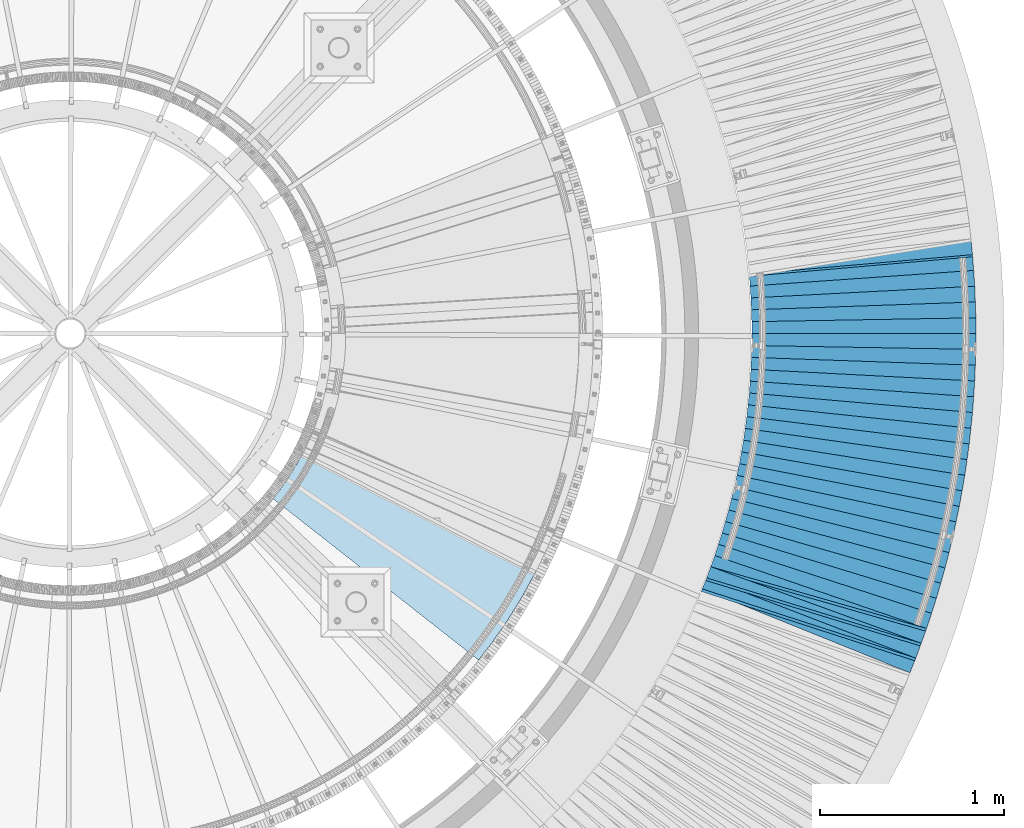
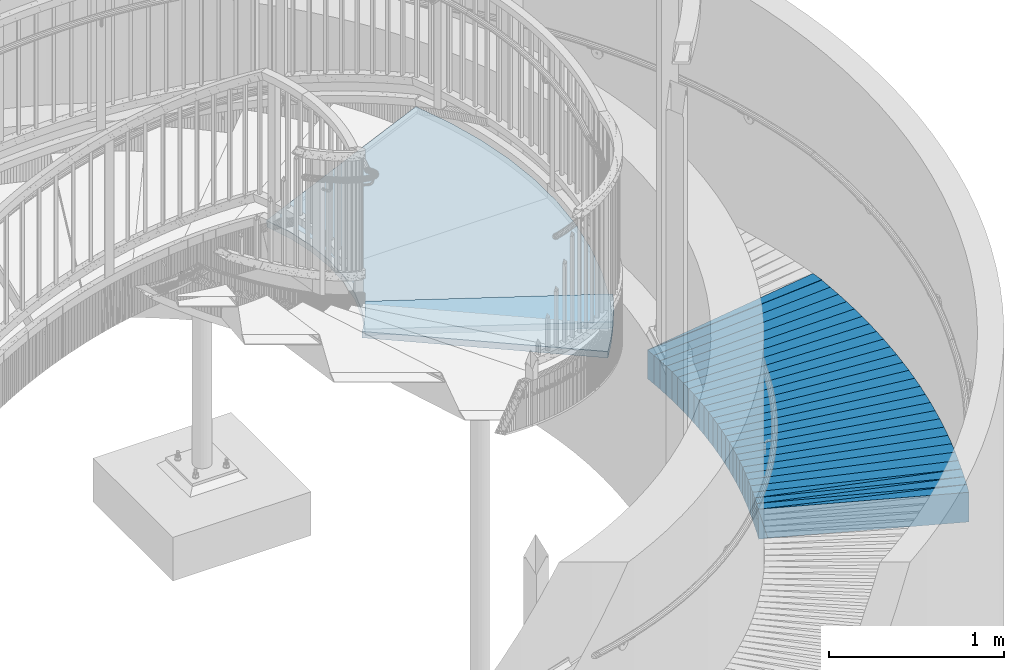
# One storey, part 834 of 975: 33 plates.
"""IFC2X3 building model written with IfcOpenShell, lengths in millimetres."""

from ifc_helpers import new_model, si_unit, frame, origin_with_axes, place, context, subcontext, project, spatial, faceted_brep, material, type_object, element, save


model = new_model("IFC2X3")

# Units and contexts
model_context = context("Model", 3, precision=1e-05, world=origin_with_axes())
body_context = subcontext(model_context, "Body", "Model", "MODEL_VIEW")
ifc_project = project(units=[si_unit("LENGTHUNIT", "METRE", prefix="MILLI"), si_unit("AREAUNIT", "SQUARE_METRE"), si_unit("VOLUMEUNIT", "CUBIC_METRE"), si_unit("MASSUNIT", "GRAM", prefix="KILO"), si_unit("TIMEUNIT", "SECOND"), si_unit("PLANEANGLEUNIT", "RADIAN"), si_unit("SOLIDANGLEUNIT", "STERADIAN"), si_unit("THERMODYNAMICTEMPERATUREUNIT", "DEGREE_CELSIUS"), si_unit("LUMINOUSINTENSITYUNIT", "LUMEN")], contexts=[model_context])

# Site, building, storey
site_placement = place(None, origin_with_axes())
site = spatial("IfcSite", under=ifc_project, at=site_placement, CompositionType="ELEMENT")
building_placement = place(site_placement, origin_with_axes())
building = spatial("IfcBuilding", under=site, at=building_placement, Name="Undefined", CompositionType="ELEMENT")
storey_placement = place(building_placement, origin_with_axes())
storey = spatial("IfcBuildingStorey", under=building, at=storey_placement, Name="Undefined", CompositionType="ELEMENT", Elevation=0.0)

# Plates
ifc_material_1 = material(Name="STEEL/A36")
plate_type_1 = type_object("IfcPlateType", PredefinedType="NOTDEFINED")
plate_1_placement = place(storey_placement, frame((39332.6635196894, 1632.35235463767, 443.468381392722), z_axis=(-0.307668717498942, -0.949732544978091, 0.0578623649879129), x_axis=(-0.951245355702387, 0.30840806390351, 0.00409137799871997)))
element("IfcPlate", 1, at=plate_1_placement, inside=storey, type_object=plate_type_1, material=ifc_material_1, Name="SLAB", context=body_context, shape_type="Brep", body=[
    faceted_brep([(-6.82121026329696e-12, -100.000000000011, -1.09139364212751e-10), (6.03959369625954, -100.000000000009, 85.9849014281099), (6.03959369680524, 100.000000000009, 85.9849014283009), (5.91171556152403e-12, 100.000000000011, 1.09139364212751e-10), (1222.0821533214, -100.000000000009, 3.27781890518963e-09), (1222.08215332196, 100.000000000009, 3.46881279256195e-09)], [[[0, 1, 2, 3]], [[1, 4, 5, 2]], [[4, 0, 3, 5]], [[5, 3, 2]], [[4, 1, 0]]]),
])
plate_2_placement = place(storey_placement, frame((39362.1973877863, 1713.21807184159, 438.56203859541), z_axis=(-0.291030701448625, -0.955028322775049, 0.0567629589767681), x_axis=(-0.956496360066036, 0.29171664402014, 0.00401407300027715)))
element("IfcPlate", 2, at=plate_2_placement, inside=storey, type_object=plate_type_1, material=ifc_material_1, Name="SLAB", context=body_context, shape_type="Brep", body=[
    faceted_brep([(-6.82121026329696e-12, -100.000000000011, -1.09139364212751e-10), (4.569957255997, -100.000000000009, 86.0007324217604), (4.56995725625893, 99.9999999999982, 86.0007324218623), (5.91171556152403e-12, 100.000000000011, 1.09139364212751e-10), (1220.70507812274, -100.000000000071, -9.877112461254e-10), (1220.705078123, 99.9999999999361, -8.85847839526832e-10)], [[[0, 1, 2, 3]], [[1, 4, 5, 2]], [[4, 0, 3, 5]], [[5, 3, 2]], [[4, 1, 0]]]),
])
plate_3_placement = place(storey_placement, frame((39391.6511921605, 1793.87534187294, 433.568651249235), z_axis=(-0.274345191219378, -0.959886074454308, 0.0579088950291885), x_axis=(-0.961426297954792, 0.275032239987067, 0.00409152399980759)))
element("IfcPlate", 3, at=plate_3_placement, inside=storey, type_object=plate_type_1, material=ifc_material_1, Name="SLAB", context=body_context, shape_type="Brep", body=[
    faceted_brep([(-6.82121026329696e-12, -100.000000000011, -1.09139364212751e-10), (6.06378555276024, -100.000000000005, 85.9140853881272), (6.063785552833, 99.999999999997, 85.9140853881327), (5.91171556152403e-12, 100.000000000011, 1.09139364212751e-10), (1222.03857421557, -100.000000000075, -2.9194779926911e-09), (1222.03857421564, 99.9999999999263, -2.91402102448046e-09)], [[[0, 1, 2, 3]], [[1, 4, 5, 2]], [[4, 0, 3, 5]], [[5, 3, 2]], [[4, 1, 0]]]),
])
plate_4_placement = place(storey_placement, frame((39420.24899421, 1881.06863383722, 433.399999999994), z_axis=(-0.309008168033193, -0.951059384102155, 0.0), x_axis=(-0.951059384102155, 0.309008168033192, 0.0)))
element("IfcPlate", 4, at=plate_4_placement, inside=storey, type_object=plate_type_1, material=ifc_material_1, Name="SLAB", context=body_context, shape_type="Brep", body=[
    faceted_brep([(-6.82121026329696e-12, -100.000000000011, -1.09139364212751e-10), (0.052212290589523, -100.0, 85.9211654663468), (0.052212290589523, 100.0, 85.9211654663468), (5.91171556152403e-12, 100.000000000011, 1.09139364212751e-10), (1219.07885742429, -100.0, 64.6703186043014), (1219.07885742429, 100.0, 64.6703186043014), (1219.06164551013, -100.0, 3.10865289065987e-09), (1219.06164551013, 100.0, 3.10865289065987e-09)], [[[0, 1, 2, 3]], [[1, 4, 5, 2]], [[4, 6, 7, 5]], [[6, 0, 3, 7]], [[5, 7, 3, 2]], [[6, 4, 1, 0]]]),
])
plate_5_placement = place(storey_placement, frame((39446.7489942099, 1962.86863383721, 433.399999999994), z_axis=(-0.292408159003419, -0.956293610011189, 0.0), x_axis=(-0.956293610011188, 0.292408159003422, 0.0)))
element("IfcPlate", 5, at=plate_5_placement, inside=storey, type_object=plate_type_1, material=ifc_material_1, Name="SLAB", context=body_context, shape_type="Brep", body=[
    faceted_brep([(-6.82121026329696e-12, -100.000000000011, -1.09139364212751e-10), (1.42279326909193, -100.0, 85.9736328124854), (1.42279326909193, 100.0, 85.9736328124854), (5.91171556152403e-12, 100.000000000011, 1.09139364212751e-10), (1220.29980468829, -100.0, 64.7558517459493), (1220.29980468829, 100.0, 64.7558517459493), (1219.18627929667, -100.000000000066, 4.07453626394272e-10), (1219.18627929667, 99.9999999999281, 3.85625753551722e-10)], [[[0, 1, 2, 3]], [[1, 4, 5, 2]], [[4, 6, 7, 5]], [[6, 0, 3, 7]], [[5, 7, 3, 2]], [[6, 4, 1, 0]]]),
])
plate_6_placement = place(storey_placement, frame((39470.4489942096, 2045.56863383732, 433.399999999994), z_axis=(-0.275631107854024, -0.961263487490898, 0.0), x_axis=(-0.961263487490899, 0.275631107854021, 0.0)))
element("IfcPlate", 6, at=plate_6_placement, inside=storey, type_object=plate_type_1, material=ifc_material_1, Name="SLAB", context=body_context, shape_type="Brep", body=[
    faceted_brep([(-6.82121026329696e-12, -100.000000000011, -1.09139364212751e-10), (-0.0127479386064806, -100.0, 86.0289459228916), (-0.0127479386064806, 100.0, 86.0289459228916), (5.91171556152403e-12, 100.000000000011, 1.09139364212751e-10), (1218.9868164098, -100.0, 64.6968231211686), (1218.9868164098, 100.0, 64.6968231211686), (1219.02062988339, -99.9999999998413, 1.29512045532465e-09), (1219.02062988328, 100.000000000125, 9.24046617001295e-10)], [[[0, 1, 2, 3]], [[1, 4, 5, 2]], [[4, 6, 7, 5]], [[6, 0, 3, 7]], [[5, 7, 3, 2]], [[6, 4, 1, 0]]]),
])
plate_7_placement = place(storey_placement, frame((39494.1489942114, 2128.26863383715, 433.399999999994), z_axis=(-0.258790751989734, -0.965933406961675, 0.0), x_axis=(-0.965933406961675, 0.258790751989733, 0.0)))
element("IfcPlate", 7, at=plate_7_placement, inside=storey, type_object=plate_type_1, material=ifc_material_1, Name="SLAB", context=body_context, shape_type="Brep", body=[
    faceted_brep([(-6.82121026329696e-12, -100.000000000011, -1.09139364212751e-10), (1.49062657373725, -100.0, 86.0160369873411), (1.49062657373725, 100.0, 86.0160369873411), (5.91171556152403e-12, 100.000000000011, 1.09139364212751e-10), (1220.32507323838, -100.0, 64.7134094229223), (1220.32507323838, 100.0, 64.7134094229223), (1219.13171386798, -99.9999999998022, 3.66708263754845e-09), (1219.13171386799, 100.000000000191, 3.72529029846191e-09)], [[[0, 1, 2, 3]], [[1, 4, 5, 2]], [[4, 6, 7, 5]], [[6, 0, 3, 7]], [[5, 7, 3, 2]], [[6, 4, 1, 0]]]),
])
plate_8_placement = place(storey_placement, frame((39515.048994212, 2211.76863383678, 433.399999999994), z_axis=(-0.24182142497303, -0.970320770891777, 0.0), x_axis=(-0.970320770891778, 0.241821424973029, 0.0)))
element("IfcPlate", 8, at=plate_8_placement, inside=storey, type_object=plate_type_1, material=ifc_material_1, Name="SLAB", context=body_context, shape_type="Brep", body=[
    faceted_brep([(-6.82121026329696e-12, -100.000000000011, -1.09139364212751e-10), (0.0876151469856268, -100.0, 86.0758514403606), (0.0876151469856268, 100.0, 86.0758514403606), (5.91171556152403e-12, 100.000000000011, 1.09139364212751e-10), (1219.03198242585, -100.0, 64.7085571301268), (1219.03198242585, 100.0, 64.7085571301268), (1219.0814209026, -100.0, -4.7839421313256e-10), (1219.0814209026, 100.0, -4.7839421313256e-10)], [[[0, 1, 2, 3]], [[1, 4, 5, 2]], [[4, 6, 7, 5]], [[6, 0, 3, 7]], [[5, 7, 3, 2]], [[6, 4, 1, 0]]]),
])
plate_9_placement = place(storey_placement, frame((39535.8489942076, 2295.16863383692, 433.399999999994), z_axis=(-0.224895447017712, -0.974382901076729, 0.0), x_axis=(-0.97438290107673, 0.22489544701771, 0.0)))
element("IfcPlate", 9, at=plate_9_placement, inside=storey, type_object=plate_type_1, material=ifc_material_1, Name="SLAB", context=body_context, shape_type="Brep", body=[
    faceted_brep([(-6.82121026329696e-12, -100.000000000011, -1.09139364212751e-10), (1.51088404672191, -100.0, 85.9413604736746), (1.51088404672191, 99.9999999999999, 85.9413604736746), (5.91171556152403e-12, 100.000000000011, 1.09139364212751e-10), (1220.40759277362, -100.0, 64.7221069334719), (1220.40759277362, 99.9999999999999, 64.7221069334719), (1219.23327636725, -100.0, 3.0740920919925e-10), (1219.23327636725, 99.9999999999999, 3.0740920919925e-10)], [[[0, 1, 2, 3]], [[1, 4, 5, 2]], [[4, 6, 7, 5]], [[6, 0, 3, 7]], [[5, 7, 3, 2]], [[6, 4, 1, 0]]]),
])
plate_10_placement = place(storey_placement, frame((39553.648994207, 2379.26863383665, 433.399999999994), z_axis=(-0.20787052900876, -0.978156349041204, 0.0), x_axis=(-0.978156349041205, 0.207870529008757, 0.0)))
element("IfcPlate", 10, at=plate_10_placement, inside=storey, type_object=plate_type_1, material=ifc_material_1, Name="SLAB", context=body_context, shape_type="Brep", body=[
    faceted_brep([(-6.82121026329696e-12, -100.000000000011, -1.09139364212751e-10), (-0.0707284805976087, -100.0, 85.9630432129179), (-0.0707284805976087, 100.0, 85.9630432129179), (5.91171556152403e-12, 100.000000000011, 1.09139364212751e-10), (1218.97717284984, -100.0, 64.7027587887696), (1218.97717284984, 100.0, 64.7027587887696), (1219.02807616998, -100.0, -6.25732354819775e-10), (1219.02807616998, 100.0, -6.25732354819775e-10)], [[[0, 1, 2, 3]], [[1, 4, 5, 2]], [[4, 6, 7, 5]], [[6, 0, 3, 7]], [[5, 7, 3, 2]], [[6, 4, 1, 0]]]),
])
plate_11_placement = place(storey_placement, frame((39571.5489942101, 2463.36863383639, 433.399999999994), z_axis=(-0.190781843953358, -0.981632460760012, 0.0), x_axis=(-0.981632460760012, 0.190781843953358, 0.0)))
element("IfcPlate", 11, at=plate_11_placement, inside=storey, type_object=plate_type_1, material=ifc_material_1, Name="SLAB", context=body_context, shape_type="Brep", body=[
    faceted_brep([(-6.82121026329696e-12, -100.000000000011, -1.09139364212751e-10), (1.52646803831885, -100.0, 85.9702835082535), (1.52646803831885, 99.9999999999999, 85.9702835082535), (5.91171556152403e-12, 100.000000000011, 1.09139364212751e-10), (1220.36914062486, -100.0, 64.7128906247071), (1220.36914062486, 99.9999999999999, 64.7128906247071), (1219.19360351495, -100.00000000027, -7.08678271621466e-09), (1219.19360351492, 99.9999999997235, -7.23230186849833e-09)], [[[0, 1, 2, 3]], [[1, 4, 5, 2]], [[4, 6, 7, 5]], [[6, 0, 3, 7]], [[5, 7, 3, 2]], [[6, 4, 1, 0]]]),
])
plate_12_placement = place(storey_placement, frame((39586.5489942077, 2548.06863383635, 433.399999999994), z_axis=(-0.173663659988655, -0.98480502293568, 0.0), x_axis=(-0.984805022935679, 0.173663659988658, 0.0)))
element("IfcPlate", 12, at=plate_12_placement, inside=storey, type_object=plate_type_1, material=ifc_material_1, Name="SLAB", context=body_context, shape_type="Brep", body=[
    faceted_brep([(-6.82121026329696e-12, -100.000000000011, -1.09139364212751e-10), (0.0627633780532051, -100.0, 86.0179367065502), (0.0627633780532051, 100.0, 86.0179367065502), (5.91171556152403e-12, 100.000000000011, 1.09139364212751e-10), (1219.07153320093, -100.0, 64.792961120409), (1219.07153320093, 100.0, 64.792961120409), (1219.02307128911, -99.9999999999895, 8.22183210402727e-10), (1219.02307128917, 100.000000000044, 1.23691279441118e-09)], [[[0, 1, 2, 3]], [[1, 4, 5, 2]], [[4, 6, 7, 5]], [[6, 0, 3, 7]], [[5, 7, 3, 2]], [[6, 4, 1, 0]]]),
])
plate_13_placement = place(storey_placement, frame((39601.4489942067, 2632.76863383641, 433.399999999994), z_axis=(-0.156413227021039, -0.987691704132856, 0.0), x_axis=(-0.987691704132856, 0.15641322702104, 0.0)))
element("IfcPlate", 13, at=plate_13_placement, inside=storey, type_object=plate_type_1, material=ifc_material_1, Name="SLAB", context=body_context, shape_type="Brep", body=[
    faceted_brep([(-6.82121026329696e-12, -100.000000000011, -1.09139364212751e-10), (1.46840608122147, -100.0, 85.988044738775), (1.46840608122147, 99.9999999999999, 85.988044738775), (5.91171556152403e-12, 100.000000000011, 1.09139364212751e-10), (1220.30493164066, -100.0, 64.6677932740458), (1220.30493164066, 99.9999999999999, 64.6677932740458), (1219.20629882823, -99.99999999996, 5.96628524363041e-10), (1219.20629882823, 100.000000000025, 4.80213202536106e-10)], [[[0, 1, 2, 3]], [[1, 4, 5, 2]], [[4, 6, 7, 5]], [[6, 0, 3, 7]], [[5, 7, 3, 2]], [[6, 4, 1, 0]]]),
])
plate_14_placement = place(storey_placement, frame((39613.448994203, 2717.86863383653, 433.399999999994), z_axis=(-0.139204557051555, -0.990263647366741, 0.0), x_axis=(-0.990263647366741, 0.139204557051554, 0.0)))
element("IfcPlate", 14, at=plate_14_placement, inside=storey, type_object=plate_type_1, material=ifc_material_1, Name="SLAB", context=body_context, shape_type="Brep", body=[
    faceted_brep([(-6.82121026329696e-12, -100.000000000011, -1.09139364212751e-10), (0.0368559846610879, -100.0, 85.9418945312664), (0.0368559846610879, 100.0, 85.9418945312664), (5.91171556152403e-12, 100.000000000011, 1.09139364212751e-10), (1219.05859374617, -100.0, 64.7287445063921), (1219.05859374617, 100.0, 64.7287445063921), (1219.06933593353, -100.0, 3.47063178196549e-09), (1219.06933593353, 100.0, 3.47063178196549e-09)], [[[0, 1, 2, 3]], [[1, 4, 5, 2]], [[4, 6, 7, 5]], [[6, 0, 3, 7]], [[5, 7, 3, 2]], [[6, 4, 1, 0]]]),
])
plate_15_placement = place(storey_placement, frame((39625.3489942044, 2803.06863383674, 433.399999999994), z_axis=(-0.121884213957514, -0.992544325654003, 0.0), x_axis=(-0.992544325654003, 0.121884213957512, 0.0)))
element("IfcPlate", 15, at=plate_15_placement, inside=storey, type_object=plate_type_1, material=ifc_material_1, Name="SLAB", context=body_context, shape_type="Brep", body=[
    faceted_brep([(-6.82121026329696e-12, -100.000000000011, -1.09139364212751e-10), (1.42674243444344, -100.0, 86.0151977538862), (1.42674243444344, 100.0, 86.0151977538862), (5.91171556152403e-12, 100.000000000011, 1.09139364212751e-10), (1220.31005858966, -100.0, 64.7190475460102), (1220.31005858966, 100.0, 64.7190475460102), (1219.18994140627, -100.000000000053, -7.20319803804159e-10), (1219.18994140625, 99.9999999999468, -8.36735125631094e-10)], [[[0, 1, 2, 3]], [[1, 4, 5, 2]], [[4, 6, 7, 5]], [[6, 0, 3, 7]], [[5, 7, 3, 2]], [[6, 4, 1, 0]]]),
])
plate_16_placement = place(storey_placement, frame((39634.3489942045, 2888.56863383688, 433.399999999994), z_axis=(-0.104595106955494, -0.994514888576822, 0.0), x_axis=(-0.994514888576822, 0.104595106955494, 0.0)))
element("IfcPlate", 16, at=plate_16_placement, inside=storey, type_object=plate_type_1, material=ifc_material_1, Name="SLAB", context=body_context, shape_type="Brep", body=[
    faceted_brep([(-6.82121026329696e-12, -100.000000000011, -1.09139364212751e-10), (0.00775234292814275, -100.0, 85.972381591775), (0.00775234292814275, 100.0, 85.972381591775), (5.91171556152403e-12, 100.000000000011, 1.09139364212751e-10), (1219.01306152048, -100.0, 64.7580032345923), (1219.01306152048, 100.0, 64.7580032345923), (1218.98632812216, -100.0, -2.18278728425503e-11), (1218.98632812216, 100.0, -2.18278728425503e-11)], [[[0, 1, 2, 3]], [[1, 4, 5, 2]], [[4, 6, 7, 5]], [[6, 0, 3, 7]], [[5, 7, 3, 2]], [[6, 4, 1, 0]]]),
])
plate_17_placement = place(storey_placement, frame((39643.3489942062, 2974.16863383697, 433.399999999994), z_axis=(-0.0871038690083005, -0.996199235094961, 0.0), x_axis=(-0.996199235094961, 0.0871038690083031, 0.0)))
element("IfcPlate", 17, at=plate_17_placement, inside=storey, type_object=plate_type_1, material=ifc_material_1, Name="SLAB", context=body_context, shape_type="Brep", body=[
    faceted_brep([(-6.82121026329696e-12, -100.000000000011, -1.09139364212751e-10), (1.50970196732669, -100.0, 86.0585861206146), (1.50970196732669, 100.0, 86.0585861206146), (5.91171556152403e-12, 100.000000000011, 1.09139364212751e-10), (1220.30773925738, -100.0, 64.6392059324771), (1220.30773925738, 100.0, 64.6392059324771), (1219.23400878922, -99.9999999998868, 1.65891833603382e-09), (1219.23400878919, 100.000000000073, 1.25874066725373e-09)], [[[0, 1, 2, 3]], [[1, 4, 5, 2]], [[4, 6, 7, 5]], [[6, 0, 3, 7]], [[5, 7, 3, 2]], [[6, 4, 1, 0]]]),
])
plate_18_placement = place(storey_placement, frame((39649.3489942035, 3059.96863383705, 433.399999999994), z_axis=(-0.0696438250024949, -0.997571921035783, 0.0), x_axis=(-0.997571921035783, 0.069643825002498, 0.0)))
element("IfcPlate", 18, at=plate_18_placement, inside=storey, type_object=plate_type_1, material=ifc_material_1, Name="SLAB", context=body_context, shape_type="Brep", body=[
    faceted_brep([(-6.82121026329696e-12, -100.000000000011, -1.09139364212751e-10), (0.00999130486889044, -100.0, 86.0095367431441), (0.00999130486889044, 100.0, 86.0095367431441), (5.91171556152403e-12, 100.000000000011, 1.09139364212751e-10), (1219.05700683402, -100.0, 64.656784057519), (1219.05700683402, 100.0, 64.656784057519), (1219.05993652157, -100.0, 3.67253960575908e-09), (1219.05993652157, 100.0, 3.67253960575908e-09)], [[[0, 1, 2, 3]], [[1, 4, 5, 2]], [[4, 6, 7, 5]], [[6, 0, 3, 7]], [[5, 7, 3, 2]], [[6, 4, 1, 0]]]),
])
plate_19_placement = place(storey_placement, frame((39655.3489942042, 3145.66863383699, 433.399999999994), z_axis=(-0.0523306630077132, -0.998629812147211, 0.0), x_axis=(-0.998629812147211, 0.0523306630077144, 0.0)))
element("IfcPlate", 19, at=plate_19_placement, inside=storey, type_object=plate_type_1, material=ifc_material_1, Name="SLAB", context=body_context, shape_type="Brep", body=[
    faceted_brep([(-6.82121026329696e-12, -100.000000000011, -1.09139364212751e-10), (1.50704109649814, -100.0, 85.8965606689253), (1.50704109649814, 100.0, 85.8965606689253), (5.91171556152403e-12, 100.000000000011, 1.09139364212751e-10), (1220.38366698803, -100.0, 64.7522048950259), (1220.38366698803, 100.0, 64.7522048950259), (1219.17053222254, -100.0, -9.12223185878247e-10), (1219.17053222254, 100.0, -9.12223185878247e-10)], [[[0, 1, 2, 3]], [[1, 4, 5, 2]], [[4, 6, 7, 5]], [[6, 0, 3, 7]], [[5, 7, 3, 2]], [[6, 4, 1, 0]]]),
])
plate_20_placement = place(storey_placement, frame((39658.3489942024, 3231.5686338371, 433.399999999994), z_axis=(-0.0349453999994803, -0.999389222985157, 0.0), x_axis=(-0.999389222985157, 0.0349453999994811, 0.0)))
element("IfcPlate", 20, at=plate_20_placement, inside=storey, type_object=plate_type_1, material=ifc_material_1, Name="SLAB", context=body_context, shape_type="Brep", body=[
    faceted_brep([(-6.82121026329696e-12, -100.000000000011, -1.09139364212751e-10), (-0.0036421960539883, -100.0, 85.9523696899341), (-0.0036421960539883, 100.0, 85.9523696899341), (5.91171556152403e-12, 100.000000000011, 1.09139364212751e-10), (1218.98229980243, -100.0, 64.7373657228018), (1218.98229980243, 100.0, 64.7373657228018), (1219.04455566161, -100.0, 4.04725142288953e-09), (1219.04455566161, 100.0, 4.04725142288953e-09)], [[[0, 1, 2, 3]], [[1, 4, 5, 2]], [[4, 6, 7, 5]], [[6, 0, 3, 7]], [[5, 7, 3, 2]], [[6, 4, 1, 0]]]),
])
plate_21_placement = place(storey_placement, frame((39661.3489942019, 3317.56863383701, 433.399999999994), z_axis=(-0.017470672002848, -0.999847376162867, 0.0), x_axis=(-0.999847376162867, 0.017470672002846, 0.0)))
element("IfcPlate", 21, at=plate_21_placement, inside=storey, type_object=plate_type_1, material=ifc_material_1, Name="SLAB", context=body_context, shape_type="Brep", body=[
    faceted_brep([(-6.82121026329696e-12, -100.000000000011, -1.09139364212751e-10), (1.49706435233384, -100.0, 86.0392837524546), (1.49706435233384, 99.9999999999999, 86.0392837524546), (5.91171556152403e-12, 100.000000000011, 1.09139364212751e-10), (1220.3553466839, -100.0, 64.7303085330045), (1220.3553466839, 99.9999999999999, 64.7303085330045), (1219.18603515645, -99.9999999996517, 4.56930138170719e-09), (1219.18603515643, 100.000000000289, 3.88536136597395e-09)], [[[0, 1, 2, 3]], [[1, 4, 5, 2]], [[4, 6, 7, 5]], [[6, 0, 3, 7]], [[5, 7, 3, 2]], [[6, 4, 1, 0]]]),
])
plate_22_placement = place(storey_placement, frame((39661.3489942005, 3403.56863383694, 433.399999999994), z_axis=(-8.20339999700081e-05, -0.999999996635211, 0.0), x_axis=(-0.999999996635212, 8.20339999699906e-05, 0.0)))
element("IfcPlate", 22, at=plate_22_placement, inside=storey, type_object=plate_type_1, material=ifc_material_1, Name="SLAB", context=body_context, shape_type="Brep", body=[
    faceted_brep([(-6.82121026329696e-12, -100.000000000011, -1.09139364212751e-10), (-0.00705496275622863, -100.0, 86.0000000000091), (-0.00705496275622863, 99.9999999999999, 86.0000000000091), (5.91171556152403e-12, 100.000000000011, 1.09139364212751e-10), (1218.99462891021, -100.0, 64.8000030515877), (1218.99462891021, 99.9999999999999, 64.8000030515877), (1219.00000000401, -100.0, 3.70300767826848e-09), (1219.00000000401, 99.9999999999999, 3.70300767826848e-09)], [[[0, 1, 2, 3]], [[1, 4, 5, 2]], [[4, 6, 7, 5]], [[6, 0, 3, 7]], [[5, 7, 3, 2]], [[6, 4, 1, 0]]]),
])
plate_23_placement = place(storey_placement, frame((39661.3489942013, 3489.56863383696, 433.399999999994), z_axis=(0.0173886749923695, -0.999848805561126, 0.0), x_axis=(-0.999848805561126, -0.0173886749923673, 0.0)))
element("IfcPlate", 23, at=plate_23_placement, inside=storey, type_object=plate_type_1, material=ifc_material_1, Name="SLAB", context=body_context, shape_type="Brep", body=[
    faceted_brep([(-6.82121026329696e-12, -100.000000000011, -1.09139364212751e-10), (1.49542605891475, -100.0, 85.9869995117233), (1.49542605891475, 100.0, 85.9869995117233), (5.91171556152403e-12, 100.000000000011, 1.09139364212751e-10), (1220.30932617596, -100.0, 64.6902160641366), (1220.30932617596, 100.0, 64.6902160641366), (1219.18432617586, -100.0, -3.12047632178292e-09), (1219.18432617586, 100.0, -3.12047632178292e-09)], [[[0, 1, 2, 3]], [[1, 4, 5, 2]], [[4, 6, 7, 5]], [[6, 0, 3, 7]], [[5, 7, 3, 2]], [[6, 4, 1, 0]]]),
])
plate_24_placement = place(storey_placement, frame((39658.3489942017, 3575.46863383701, 433.399999999994), z_axis=(0.0348634679832394, -0.999392084519475, 0.0), x_axis=(-0.999392084519475, -0.0348634679832369, 0.0)))
element("IfcPlate", 24, at=plate_24_placement, inside=storey, type_object=plate_type_1, material=ifc_material_1, Name="SLAB", context=body_context, shape_type="Brep", body=[
    faceted_brep([(-6.82121026329696e-12, -100.000000000011, -1.09139364212751e-10), (-0.00340431531367358, -100.0, 85.9523696899441), (-0.00340431531367358, 100.0, 85.9523696899441), (5.91171556152403e-12, 100.000000000011, 1.09139364212751e-10), (1218.99462891018, -100.0, 64.6409149166743), (1218.99462891018, 100.0, 64.6409149166743), (1219.04101562503, -100.000000000035, -4.58385329693556e-10), (1219.04101562505, 100.000000000007, 1.60071067512035e-10)], [[[0, 1, 2, 3]], [[1, 4, 5, 2]], [[4, 6, 7, 5]], [[6, 0, 3, 7]], [[5, 7, 3, 2]], [[6, 4, 1, 0]]]),
])
plate_25_placement = place(storey_placement, frame((39655.3489942016, 3661.468633837, 433.399999999994), z_axis=(0.0523306630077132, -0.998629812147211, 0.0), x_axis=(-0.998629812147211, -0.0523306630077144, 0.0)))
element("IfcPlate", 25, at=plate_25_placement, inside=storey, type_object=plate_type_1, material=ifc_material_1, Name="SLAB", context=body_context, shape_type="Brep", body=[
    faceted_brep([(-6.82121026329696e-12, -100.000000000011, -1.09139364212751e-10), (1.50454759613785, -100.0, 86.0391540527162), (1.50454759613785, 100.0, 86.0391540527162), (5.91171556152403e-12, 100.000000000011, 1.09139364212751e-10), (1220.35925292579, -100.0, 64.7264785766242), (1220.35925292579, 100.0, 64.7264785766242), (1219.17053222254, -100.0, -9.12223185878247e-10), (1219.17053222254, 100.0, -9.12223185878247e-10)], [[[0, 1, 2, 3]], [[1, 4, 5, 2]], [[4, 6, 7, 5]], [[6, 0, 3, 7]], [[5, 7, 3, 2]], [[6, 4, 1, 0]]]),
])
plate_26_placement = place(storey_placement, frame((39649.3489942016, 3747.268633837, 433.399999999994), z_axis=(0.0698070879774386, -0.997560509677538, 0.0), x_axis=(-0.997560509677539, -0.0698070879774351, 0.0)))
element("IfcPlate", 26, at=plate_26_placement, inside=storey, type_object=plate_type_1, material=ifc_material_1, Name="SLAB", context=body_context, shape_type="Brep", body=[
    faceted_brep([(-6.82121026329696e-12, -100.000000000011, -1.09139364212751e-10), (0.00408506784151541, -100.0, 86.009536743175), (0.00408506784151541, 100.0, 86.009536743175), (5.91171556152403e-12, 100.000000000011, 1.09139364212751e-10), (1218.98767089756, -100.0, 64.6637649538102), (1218.98767089756, 100.0, 64.6637649538102), (1219.07397460871, -100.0, -8.27640178613365e-11), (1219.07397460871, 100.0, -8.27640178613365e-11)], [[[0, 1, 2, 3]], [[1, 4, 5, 2]], [[4, 6, 7, 5]], [[6, 0, 3, 7]], [[5, 7, 3, 2]], [[6, 4, 1, 0]]]),
])
plate_27_placement = place(storey_placement, frame((39643.3489942016, 3833.068633837, 433.399999999994), z_axis=(0.0871852639892386, -0.996192114877009, 0.0), x_axis=(-0.996192114877009, -0.0871852639892363, 0.0)))
element("IfcPlate", 27, at=plate_27_placement, inside=storey, type_object=plate_type_1, material=ifc_material_1, Name="SLAB", context=body_context, shape_type="Brep", body=[
    faceted_brep([(-6.82121026329696e-12, -100.000000000011, -1.09139364212751e-10), (1.50334298602684, -100.0, 85.9963912963908), (1.50334298602684, 100.0, 85.9963912963908), (5.91171556152403e-12, 100.000000000011, 1.09139364212751e-10), (1220.39208984587, -100.0, 64.746345519959), (1220.39208984587, 100.0, 64.746345519959), (1219.24267578343, -100.0, -5.67524693906307e-10), (1219.24267578343, 100.0, -5.67524693906307e-10)], [[[0, 1, 2, 3]], [[1, 4, 5, 2]], [[4, 6, 7, 5]], [[6, 0, 3, 7]], [[5, 7, 3, 2]], [[6, 4, 1, 0]]]),
])
plate_28_placement = place(storey_placement, frame((39634.8935925812, 3912.80601801554, 430.918743097096), z_axis=(0.157085544202833, -0.98588482722759, 0.0579244270142165), x_axis=(-0.987572022796093, -0.15711373096756, 0.00409576999915435)))
element("IfcPlate", 28, at=plate_28_placement, inside=storey, type_object=plate_type_1, material=ifc_material_1, Name="SLAB", context=body_context, shape_type="Brep", body=[
    faceted_brep([(-6.82121026329696e-12, -100.000000000011, -1.09139364212751e-10), (4.56555461898097, -99.9999999999999, 85.9965438842232), (4.56555461841344, 100.000000000002, 85.9965438843419), (5.91171556152403e-12, 100.000000000011, 1.09139364212751e-10), (1220.77172851307, -99.9999999999752, 6.26641849521548e-10), (1220.7717285125, 100.000000000027, 7.44876160752028e-10)], [[[0, 1, 2, 3]], [[1, 4, 5, 2]], [[4, 0, 3, 5]], [[5, 3, 2]], [[4, 1, 0]]]),
])
plate_type_2 = type_object("IfcPlateType", PredefinedType="NOTDEFINED")
plate_29_placement = place(storey_placement, frame((39332.0764467383, 1630.53989582668, 443.597065418759), z_axis=(-0.357293351468463, -0.930810924663495, 0.0770226169610157), x_axis=(-0.933584280685784, 0.358357908879387, 0.0)))
element("IfcPlate", 29, at=plate_29_placement, inside=storey, type_object=plate_type_2, material=ifc_material_1, Name="SLAB", context=body_context, shape_type="Brep", body=[
    faceted_brep([(-6.82121026329696e-12, -100.000000000011, -1.09139364212751e-10), (1220.35681152316, -100.000000000205, 64.9160003634752), (1220.35681152318, 99.9999999998349, 64.9160003640791), (5.91171556152403e-12, 100.000000000011, 1.09139364212751e-10), (1219.17224121067, -100.000000000208, -4.02360456064343e-09), (1219.17224121068, 99.9999999998308, -3.41242412105203e-09)], [[[0, 1, 2, 3]], [[1, 4, 5, 2]], [[4, 0, 3, 5]], [[5, 3, 2]], [[4, 1, 0]]]),
])
plate_30_placement = place(storey_placement, frame((39361.6535824076, 1711.43331267664, 438.685626034943), z_axis=(-0.341023090231204, -0.937015949417642, 0.0755272299645391), x_axis=(-0.939699977198368, 0.341999931072196, 0.0)))
element("IfcPlate", 30, at=plate_30_placement, inside=storey, type_object=plate_type_2, material=ifc_material_1, Name="SLAB", context=body_context, shape_type="Brep", body=[
    faceted_brep([(-6.82121026329696e-12, -100.000000000011, -1.09139364212751e-10), (1218.97985839977, -99.9999999999677, 64.8772659306323), (1218.97985840021, 100.000000000045, 64.8772659307742), (5.91171556152403e-12, 100.000000000011, 1.09139364212751e-10), (1219.00610351704, -99.9999999999638, 2.39924702327698e-09), (1219.00610351748, 100.000000000048, 2.53930920735002e-09)], [[[0, 1, 2, 3]], [[1, 4, 5, 2]], [[4, 0, 3, 5]], [[5, 3, 2]], [[4, 1, 0]]]),
])
plate_31_placement = place(storey_placement, frame((39391.127668234, 1792.04335083127, 433.697436828473), z_axis=(-0.324569913463689, -0.942716543591611, 0.0770706799818193), x_axis=(-0.945528894753246, 0.325538183915044, 0.0)))
element("IfcPlate", 31, at=plate_31_placement, inside=storey, type_object=plate_type_2, material=ifc_material_1, Name="SLAB", context=body_context, shape_type="Brep", body=[
    faceted_brep([(-6.82121026329696e-12, -100.000000000011, -1.09139364212751e-10), (1220.31530761401, -100.00000000009, 64.8755111682531), (1220.31530761337, 99.9999999998886, 64.8755111680312), (5.91171556152403e-12, 100.000000000011, 1.09139364212751e-10), (1219.21179199108, -100.000000000276, -3.688910510391e-09), (1219.21179199089, 99.9999999996767, -4.27098711952567e-09)], [[[0, 1, 2, 3]], [[1, 4, 5, 2]], [[4, 0, 3, 5]], [[5, 3, 2]], [[4, 1, 0]]]),
])
ifc_material_2 = material(Name="STEEL/Zero_Density")
plate_type_3 = type_object("IfcPlateType", PredefinedType="NOTDEFINED")
plate_32_placement = place(storey_placement, frame((36002.0777819101, 2758.13395238831, 2289.175), z_axis=(0.865608154191222, -0.500722002110618, 0.0), x_axis=(-0.500722002110617, -0.865608154191223, 0.0)))
element("IfcPlate", 32, at=plate_32_placement, inside=storey, type_object=plate_type_3, material=ifc_material_2, Name="CONC.", context=body_context, shape_type="Brep", body=[
    faceted_brep([(226.607026755963, -22.2249999999999, -5.9806827134089), (151.21244687953, -22.2249999999999, 0.0171956564081484), (151.21244687953, 22.2249999999999, 0.0171956564081484), (226.607026755963, 22.2249999999999, -5.9806827134089), (75.6059955448145, -22.2249999999999, 2.01262449634305), (75.6059955448145, 22.2249999999999, 2.01262449634305), (0.0, -22.2249999999999, 0.0), (6.3512526843333, 22.2249999999999, 0.169069749597838), (-75.9923477177144, -22.2249999999999, 1420.59179687598), (-69.6411756631605, 22.2249999999999, 1420.76237488879), (75.2887648406067, -22.2249999999999, 1424.6548629265), (75.2887648406067, 22.2249999999999, 1424.6548629265), (226.570657118533, -22.2249999999999, 1420.62093290526), (226.570657118533, 22.2249999999999, 1420.62093290526), (377.420264969449, -22.2249999999999, 1408.50155446305), (377.420264969449, 22.2249999999999, 1408.50155446305), (501.974970329931, -22.2249999999999, 1391.75136796272), (501.974970329931, 22.2249999999999, 1391.75136796272), (301.578002929167, 22.2249999999999, -15.9641666403222), (301.578002929167, -22.2249999999999, -15.9641666403222)], [[[0, 1, 2, 3]], [[1, 4, 5, 2]], [[5, 4, 6, 7]], [[8, 9, 7, 6]], [[10, 11, 9, 8]], [[10, 12, 13, 11]], [[12, 14, 15, 13]], [[15, 14, 16, 17]], [[3, 2, 5, 7, 9, 11, 13, 15, 17, 18]], [[0, 3, 18, 19]], [[14, 12, 10, 8, 6, 4, 1, 0, 19, 16]], [[18, 17, 16, 19]]]),
])
plate_type_4 = type_object("IfcPlateType", PredefinedType="NOTDEFINED")
plate_33_placement = place(storey_placement, frame((36043.7195583564, 3959.76903889786, 2111.375), z_axis=(0.980103929565302, 0.198484979911965, 0.0), x_axis=(0.198484979911964, -0.980103929565302, 0.0)))
element("IfcPlate", 33, at=plate_33_placement, inside=storey, type_object=plate_type_4, material=ifc_material_2, Name="CONC.", context=body_context, shape_type="Brep", body=[
    faceted_brep([(-37.6723473739453, -22.2249999999999, 1434.0153465979), (212.533593447421, -22.2249999999999, 1452.12748038145), (212.533593447421, 22.2249999999999, 1452.12748038145), (-37.6723473739453, 22.2249999999999, 1434.0153465979), (463.358936626287, -22.2249999999999, 1447.91922281959), (463.358936626287, 22.2249999999999, 1447.91922281959), (712.816469800558, -22.2249999999999, 1421.42391464793), (712.816469800558, 22.2249999999999, 1421.42391464793), (958.92981734783, -22.2249999999999, 1372.85147007718), (958.92981734783, 22.2249999999999, 1372.85147007718), (1199.74909860403, -22.2249999999999, 1302.58671370713), (1199.74909860403, 22.2249999999999, 1302.58671370713), (1433.36637617067, -22.2249999999999, 1211.18633167924), (1433.36637617067, 22.2249999999999, 1211.18633167924), (1657.93077191838, -22.2249999999999, 1099.37446122291), (1657.93077191838, 22.2249999999999, 1099.37446122291), (1871.6631309274, -22.2249999999999, 968.036953537936), (1871.6631309274, 22.2249999999999, 968.036953537936), (2072.87011718724, -22.2249999999999, 818.214355467106), (2072.87011718724, 22.2249999999999, 818.214355467106), (1189.19250488288, -22.2249999999999, -295.255737304258), (1189.19250488288, 22.2249999999999, -295.255737304258), (1042.40732045188, -22.2249999999999, -189.712737792397), (1042.40732045188, 22.2249999999999, -189.712737792397), (883.464398252189, -22.2249999999999, -103.559603217742), (883.464398252189, 22.2249999999999, -103.559603217742), (714.910783428954, -22.2249999999999, -38.1769293320322), (714.910783428954, 22.2249999999999, -38.1769293320322), (539.447531558546, -22.2249999999999, 5.38753276142234), (539.447531558546, 22.2249999999999, 5.38753276142234), (359.886424490973, -22.2249999999999, 26.4356667191169), (359.886424490973, 22.2249999999999, 26.4356667191169), (179.104911814324, -22.2249999999999, 24.6301782049777), (179.104911814324, 22.2249999999999, 24.6301782049777), (6.30541715009394, 22.2249999999999, 0.867109374550637), (-279.002642238658, 22.2249999999999, 1394.74718494229), (-285.276580810932, -22.2249999999999, 1393.72631835689), (0.0, -22.2249999999999, 0.0)], [[[0, 1, 2, 3]], [[1, 4, 5, 2]], [[4, 6, 7, 5]], [[6, 8, 9, 7]], [[8, 10, 11, 9]], [[10, 12, 13, 11]], [[12, 14, 15, 13]], [[14, 16, 17, 15]], [[16, 18, 19, 17]], [[18, 20, 21, 19]], [[20, 22, 23, 21]], [[22, 24, 25, 23]], [[24, 26, 27, 25]], [[26, 28, 29, 27]], [[28, 30, 31, 29]], [[30, 32, 33, 31]], [[3, 2, 5, 7, 9, 11, 13, 15, 17, 19, 21, 23, 25, 27, 29, 31, 33, 34, 35]], [[0, 3, 35, 36]], [[32, 30, 28, 26, 24, 22, 20, 18, 16, 14, 12, 10, 8, 6, 4, 1, 0, 36, 37]], [[33, 32, 37, 34]], [[36, 35, 34, 37]]]),
])

save(model, "model.ifc")
